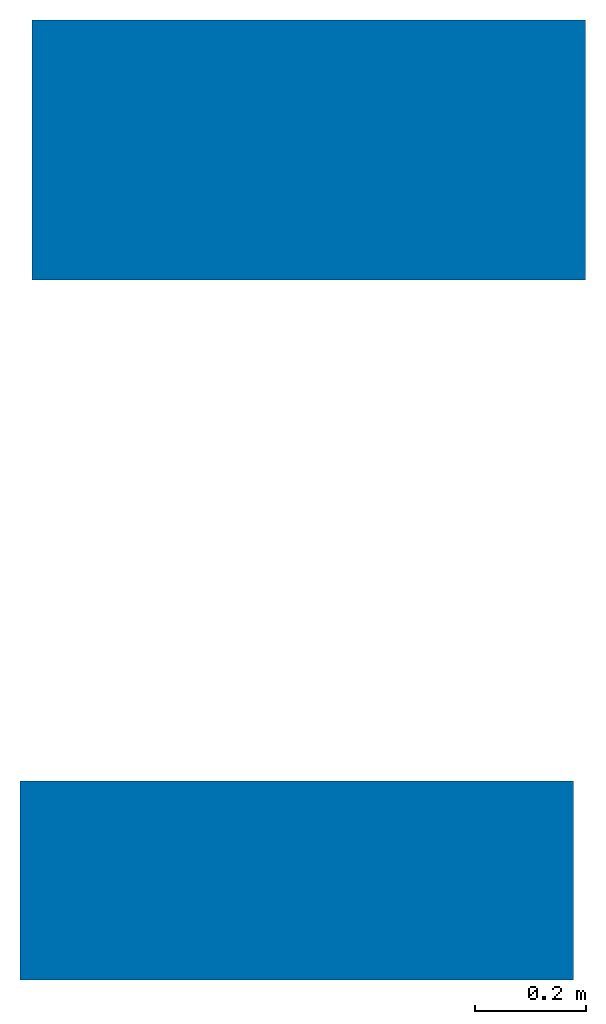
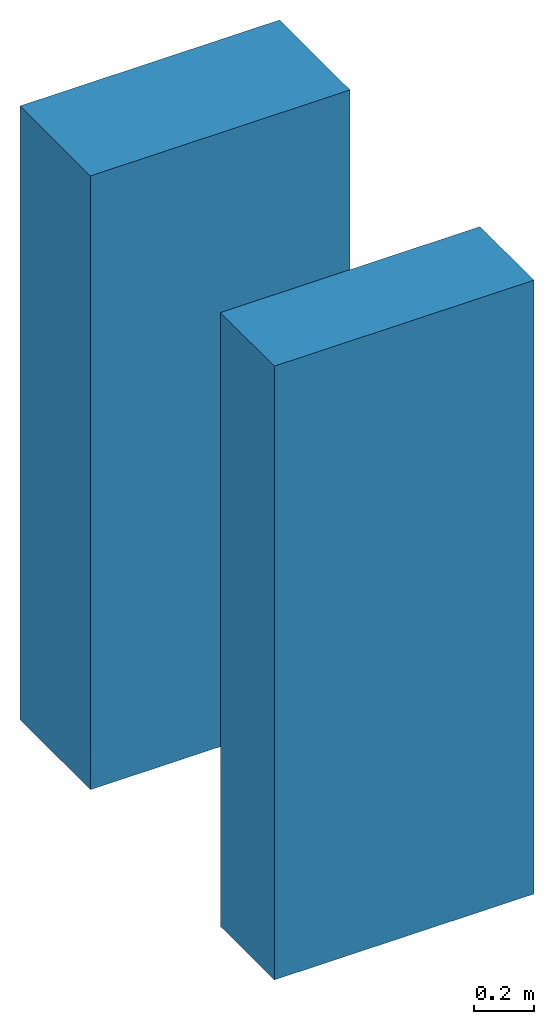
# One storey: 2 walls.
"""IFC2X3 building model written with IfcOpenShell, lengths in metres."""

from ifc_helpers import new_model, entity, si_unit, converted_unit, frame, frame_2d, origin, origin_with_axes, place, context, subcontext, project, spatial, rectangle, extrude, material, layer, layer_set, layer_usage, element, save


model = new_model("IFC2X3")

# Units and contexts
model_context = context("Model", 3, precision=1e-05, world=origin())
body_context = subcontext(model_context, "Body", "Model", "MODEL_VIEW")
ifc_project = project(units=[si_unit("LENGTHUNIT", "METRE"), converted_unit("PLANEANGLEUNIT", "DEGREE", entity("IfcPlaneAngleMeasure", 0.0174532925199433), si_unit("PLANEANGLEUNIT", "RADIAN"), dimensions=[0, 0, 0, 0, 0, 0, 0]), si_unit("AREAUNIT", "SQUARE_METRE"), si_unit("VOLUMEUNIT", "CUBIC_METRE")], contexts=[model_context])

# Site, building, storey
site_placement = place(None, origin())
site = spatial("IfcSite", under=ifc_project, at=site_placement, CompositionType="ELEMENT")
building_placement = place(site_placement, origin_with_axes())
building = spatial("IfcBuilding", under=site, at=building_placement, Name="Default Building", CompositionType="ELEMENT")
storey_placement = place(building_placement, origin_with_axes())
storey = spatial("IfcBuildingStorey", under=building, at=storey_placement, Name="Default Storey", CompositionType="ELEMENT", Elevation=0.0)

# Walls
ifc_material_1 = material(Name="Backstein")
ifc_layer_1 = layer(ifc_material_1, 0.15)
ifc_material_2 = material()
ifc_layer_2 = layer(ifc_material_2, 0.12)
ifc_material_3 = material(Name="Ortbeton")
ifc_layer_3 = layer(ifc_material_3, 0.2)
ifc_layer_set_1 = layer_set([ifc_layer_1, ifc_layer_2, ifc_layer_3])
ifc_layer_usage_1 = layer_usage(ifc_layer_set_1, "AXIS2", "POSITIVE", -0.47)
wall_1_placement = place(storey_placement, frame((-4.665670146818928, 3.568094747145195, 0.0), z_axis=(0.0, 0.0, 1.0), x_axis=(1.0, 0.0, 0.0)))
element("IfcWallStandardCase", 1, at=wall_1_placement, inside=storey, material=ifc_layer_usage_1, Name="Wand", context=body_context, shape_type="SweptSolid", body=[
    extrude(rectangle(XDim=1.0, YDim=0.47, at=frame_2d((0.5, 0.235), x_axis=(1.0, 0.0))), origin_with_axes(), (0.0, 0.0, 1.0), 2.5),
])
ifc_material_4 = material(Name="Beton")
ifc_layer_4 = layer(ifc_material_4, 0.06)
ifc_material_5 = material(Name="Ortbeton")
ifc_layer_5 = layer(ifc_material_5, 0.17)
ifc_material_6 = material()
ifc_layer_6 = layer(ifc_material_6, 0.08)
ifc_material_7 = material(Name="Beton")
ifc_layer_7 = layer(ifc_material_7, 0.05)
ifc_layer_set_2 = layer_set([ifc_layer_4, ifc_layer_5, ifc_layer_6, ifc_layer_7])
ifc_layer_usage_2 = layer_usage(ifc_layer_set_2, "AXIS2", "POSITIVE", 0.0)
wall_2_placement = place(storey_placement, frame((-4.687634257748782, 2.302929983686787, 0.0), z_axis=(0.0, 0.0, 1.0), x_axis=(1.0, 0.0, 0.0)))
element("IfcWallStandardCase", 2, at=wall_2_placement, inside=storey, material=ifc_layer_usage_2, Name="Wand", context=body_context, shape_type="SweptSolid", body=[
    extrude(rectangle(XDim=1.0, YDim=0.36, at=frame_2d((0.5, 0.18), x_axis=(1.0, 0.0))), origin_with_axes(), (0.0, 0.0, 1.0), 2.5),
])

save(model, "model.ifc")
